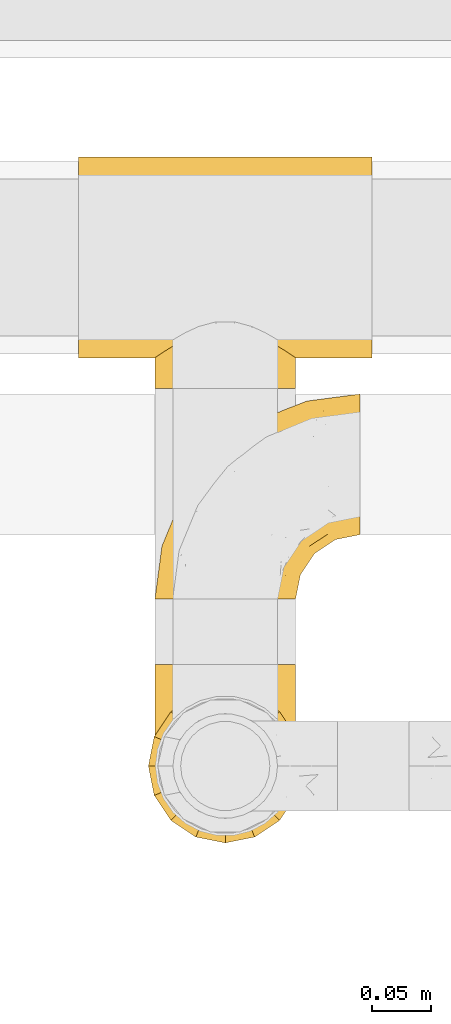
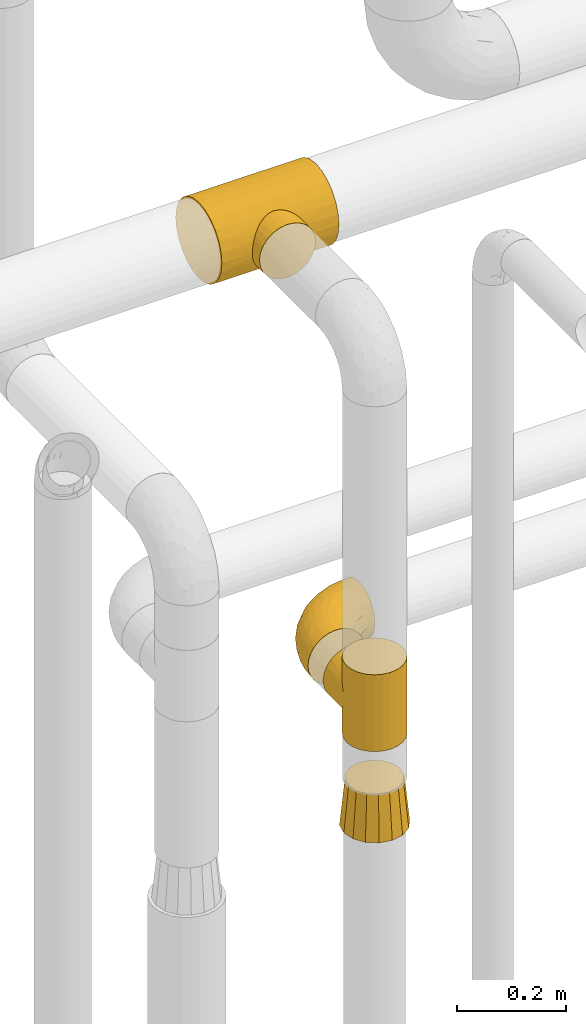
# One storey, part 460 of 827: 4 coverings.
"""IFC2X3 building model written with IfcOpenShell, lengths in millimetres."""

from ifc_helpers import new_model, entity, si_unit, converted_unit, derived_unit, direction, frame, origin, place, context, subcontext, project, spatial, faceted_brep, element, save


model = new_model("IFC2X3")

# Units and contexts
model_context = context("Model", 3, precision=0.01, world=origin(), true_north=direction((6.12303176911189e-17, 1.0)))
body_context = subcontext(model_context, "Body", "Model", "MODEL_VIEW")
ifc_project = project(units=[si_unit("LENGTHUNIT", "METRE", prefix="MILLI"), si_unit("AREAUNIT", "SQUARE_METRE"), si_unit("VOLUMEUNIT", "CUBIC_METRE"), converted_unit("PLANEANGLEUNIT", "DEGREE", entity("IfcRatioMeasure", 0.0174532925199433), si_unit("PLANEANGLEUNIT", "RADIAN"), dimensions=[0, 0, 0, 0, 0, 0, 0]), si_unit("MASSUNIT", "GRAM", prefix="KILO"), derived_unit("MASSDENSITYUNIT", [(si_unit("MASSUNIT", "GRAM", prefix="KILO"), 1), (si_unit("LENGTHUNIT", "METRE"), -3)]), derived_unit("MOMENTOFINERTIAUNIT", [(si_unit("LENGTHUNIT", "METRE"), 4)]), si_unit("TIMEUNIT", "SECOND"), si_unit("FREQUENCYUNIT", "HERTZ"), si_unit("THERMODYNAMICTEMPERATUREUNIT", "DEGREE_CELSIUS"), derived_unit("THERMALTRANSMITTANCEUNIT", [(si_unit("MASSUNIT", "GRAM", prefix="KILO"), 1), (si_unit("THERMODYNAMICTEMPERATUREUNIT", "KELVIN"), -1), (si_unit("TIMEUNIT", "SECOND"), -3)]), derived_unit("VOLUMETRICFLOWRATEUNIT", [(si_unit("LENGTHUNIT", "METRE"), 3), (si_unit("TIMEUNIT", "SECOND"), -1)]), derived_unit("MASSFLOWRATEUNIT", [(si_unit("MASSUNIT", "GRAM", prefix="KILO"), 1), (si_unit("TIMEUNIT", "SECOND"), -1)]), derived_unit("ROTATIONALFREQUENCYUNIT", [(si_unit("TIMEUNIT", "SECOND"), -1)]), si_unit("ELECTRICCURRENTUNIT", "AMPERE"), si_unit("ELECTRICVOLTAGEUNIT", "VOLT"), si_unit("POWERUNIT", "WATT"), si_unit("FORCEUNIT", "NEWTON", prefix="KILO"), si_unit("ILLUMINANCEUNIT", "LUX"), si_unit("LUMINOUSFLUXUNIT", "LUMEN"), si_unit("LUMINOUSINTENSITYUNIT", "CANDELA"), derived_unit("USERDEFINED", [(si_unit("MASSUNIT", "GRAM", prefix="KILO"), -1), (si_unit("LENGTHUNIT", "METRE"), -2), (si_unit("TIMEUNIT", "SECOND"), 3), (si_unit("LUMINOUSFLUXUNIT", "LUMEN"), 1)]), derived_unit("LINEARVELOCITYUNIT", [(si_unit("LENGTHUNIT", "METRE"), 1), (si_unit("TIMEUNIT", "SECOND"), -1)]), si_unit("PRESSUREUNIT", "PASCAL"), derived_unit("USERDEFINED", [(si_unit("LENGTHUNIT", "METRE"), -2), (si_unit("MASSUNIT", "GRAM", prefix="KILO"), 1), (si_unit("TIMEUNIT", "SECOND"), -2)]), derived_unit("LINEARFORCEUNIT", [(si_unit("MASSUNIT", "GRAM", prefix="KILO"), 1), (si_unit("LENGTHUNIT", "METRE"), 1), (si_unit("TIMEUNIT", "SECOND"), -2), (si_unit("LENGTHUNIT", "METRE"), -1)]), derived_unit("PLANARFORCEUNIT", [(si_unit("MASSUNIT", "GRAM", prefix="KILO"), 1), (si_unit("LENGTHUNIT", "METRE"), 1), (si_unit("TIMEUNIT", "SECOND"), -2), (si_unit("LENGTHUNIT", "METRE"), -2)])], contexts=[model_context])

# Site, building, storey
site_placement = place(None, origin())
site = spatial("IfcSite", under=ifc_project, at=site_placement, CompositionType="ELEMENT")
building_placement = place(site_placement, origin())
building = spatial("IfcBuilding", under=site, at=building_placement, CompositionType="ELEMENT")
storey_placement = place(building_placement, frame((0.0, 0.0, 28200.0)))
storey = spatial("IfcBuildingStorey", under=building, at=storey_placement, Name="08", CompositionType="ELEMENT", Elevation=28200.0)

# Coverings
covering_1_placement = place(storey_placement, frame((57386.84, 17438.95, 2014.0)))
element("IfcCovering", 1, at=covering_1_placement, inside=storey, Name=":ADSK_", ObjectType=":ADSK_", PredefinedType="INSULATION", context=body_context, shape_type="Brep", body=[
    faceted_brep([(119.95, 69.05, 77.99), (120.5, 61.05, 0.0), (118.47, 76.43, 0.0), (112.53, 90.77, 0.0), (115.56, 84.76, 62.29), (106.45, 99.42, 47.63), (103.08, 103.08, 0.0), (111.63, 92.28, 54.76), (120.5, 61.05, 86.0), (119.95, 69.05, 94.01), (120.5, 61.05, 172.0), (118.32, 76.98, 70.06), (99.95, 106.0, 41.05), (90.77, 112.53, 0.0), (82.79, 116.38, 30.67), (83.6, 115.5, 0.0), (76.43, 118.47, 0.0), (68.74, 119.48, 0.0), (61.05, 120.5, 0.0), (61.05, 120.5, 26.55), (68.74, 119.48, 172.0), (61.05, 120.5, 145.45), (61.05, 120.5, 172.0), (92.06, 111.76, 35.28), (72.29, 119.42, 27.62), (49.81, 119.42, 27.62), (53.35, 119.48, 0.0), (45.66, 118.47, 0.0), (39.31, 116.38, 30.66), (38.49, 115.5, 0.0), (31.32, 112.53, 0.0), (22.14, 106.0, 41.04), (19.01, 103.08, 0.0), (53.35, 119.48, 172.0), (30.03, 111.77, 35.28), (15.65, 99.43, 47.62), (10.47, 92.29, 54.76), (9.56, 90.77, 0.0), (6.53, 84.76, 62.28), (3.62, 76.43, 0.0), (2.14, 69.05, 77.99), (1.6, 61.05, 0.0), (3.77, 76.99, 70.06), (1.6, 61.05, 86.0), (2.14, 69.05, 94.01), (1.6, 61.05, 172.0), (31.32, 9.56, 172.0), (45.66, 3.62, 172.0), (61.05, 1.6, 172.0), (76.43, 3.62, 172.0), (90.77, 9.56, 172.0), (103.08, 19.01, 172.0), (112.53, 31.32, 172.0), (118.47, 45.66, 172.0), (118.47, 76.43, 172.0), (112.53, 90.77, 172.0), (103.08, 103.08, 172.0), (90.77, 112.53, 172.0), (83.6, 115.5, 172.0), (76.43, 118.47, 172.0), (45.66, 118.47, 172.0), (38.49, 115.5, 172.0), (31.32, 112.53, 172.0), (19.01, 103.08, 172.0), (9.56, 90.77, 172.0), (3.62, 76.43, 172.0), (3.62, 45.66, 172.0), (9.56, 31.32, 172.0), (19.01, 19.01, 172.0), (118.47, 45.66, 0.0), (112.53, 31.32, 0.0), (103.08, 19.01, 0.0), (90.77, 9.56, 0.0), (76.43, 3.62, 0.0), (61.05, 1.6, 0.0), (45.66, 3.62, 0.0), (31.32, 9.56, 0.0), (19.01, 19.01, 0.0), (9.56, 31.32, 0.0), (3.62, 45.66, 0.0), (118.32, 76.98, 101.94), (115.56, 84.76, 109.71), (111.63, 92.28, 117.24), (106.45, 99.42, 124.37), (99.95, 106.0, 130.95), (92.06, 111.76, 136.72), (82.79, 116.38, 141.33), (72.29, 119.42, 144.38), (49.81, 119.42, 144.38), (39.31, 116.38, 141.34), (30.03, 111.77, 136.72), (22.14, 106.0, 130.96), (15.65, 99.43, 124.38), (6.53, 84.76, 109.72), (3.77, 76.99, 101.94), (10.47, 92.29, 117.24), (120.5, 147.05, 86.0), (118.47, 147.05, 70.61), (112.53, 147.05, 56.27), (103.08, 147.05, 43.96), (90.77, 147.05, 34.51), (83.6, 147.05, 31.55), (76.43, 147.05, 28.58), (68.74, 147.05, 27.56), (61.05, 147.05, 26.55), (53.35, 147.05, 27.56), (45.66, 147.05, 28.58), (38.49, 147.05, 31.55), (31.32, 147.05, 34.51), (19.01, 147.05, 43.96), (9.56, 147.05, 56.27), (3.62, 147.05, 70.61), (1.6, 147.05, 86.0), (3.62, 147.05, 101.39), (9.56, 147.05, 115.72), (19.01, 147.05, 128.04), (31.32, 147.05, 137.49), (38.49, 147.05, 140.45), (45.66, 147.05, 143.42), (53.35, 147.05, 144.44), (61.05, 147.05, 145.45), (68.74, 147.05, 144.44), (76.43, 147.05, 143.42), (83.6, 147.05, 140.45), (90.77, 147.05, 137.49), (103.08, 147.05, 128.04), (112.53, 147.05, 115.72), (118.47, 147.05, 101.39)], [[[0, 1, 2]], [[2, 3, 4]], [[5, 3, 6]], [[5, 7, 3]], [[0, 8, 1]], [[8, 9, 10]], [[4, 11, 2]], [[7, 4, 3]], [[0, 2, 11]], [[12, 6, 13]], [[14, 13, 15, 16]], [[17, 18, 19]], [[20, 21, 22]], [[23, 12, 13]], [[24, 14, 16]], [[24, 17, 19]], [[24, 16, 17]], [[23, 13, 14]], [[6, 12, 5]], [[25, 26, 27]], [[28, 27, 29, 30]], [[31, 30, 32]], [[19, 26, 25]], [[19, 18, 26]], [[22, 21, 33]], [[34, 28, 30]], [[31, 34, 30]], [[25, 27, 28]], [[32, 35, 31]], [[36, 35, 37]], [[37, 35, 32]], [[38, 37, 39]], [[40, 39, 41]], [[38, 36, 37]], [[40, 42, 39]], [[43, 40, 41]], [[44, 43, 45]], [[38, 39, 42]], [[46, 47, 48, 49, 50, 51, 52, 53, 10, 54, 55, 56, 57, 58, 59, 20, 22, 33, 60, 61, 62, 63, 64, 65, 45, 66, 67, 68]], [[1, 69, 70, 71, 72, 73, 74, 75, 76, 77, 78, 79, 41, 39, 37, 32, 30, 29, 27, 26, 18, 17, 16, 15, 13, 6, 3, 2]], [[72, 71, 51, 50]], [[48, 74, 73, 49]], [[49, 73, 72, 50]], [[52, 70, 69, 53]], [[1, 8, 10, 53, 69]], [[51, 71, 70, 52]], [[80, 81, 54]], [[9, 80, 54]], [[10, 9, 54]], [[55, 82, 83]], [[55, 54, 81]], [[55, 83, 56]], [[82, 55, 81]], [[84, 85, 57]], [[86, 59, 58, 57]], [[86, 87, 59]], [[21, 20, 87]], [[85, 86, 57]], [[56, 84, 57]], [[87, 20, 59]], [[84, 56, 83]], [[88, 89, 60]], [[88, 60, 33]], [[90, 91, 62]], [[89, 62, 61, 60]], [[89, 90, 62]], [[88, 33, 21]], [[91, 63, 62]], [[91, 92, 63]], [[93, 94, 65]], [[94, 44, 65]], [[92, 95, 64]], [[93, 64, 95]], [[93, 65, 64]], [[44, 45, 65]], [[92, 64, 63]], [[43, 41, 79, 66, 45]], [[66, 79, 78, 67]], [[78, 77, 68, 67]], [[68, 77, 76, 46]], [[46, 76, 75, 47]], [[47, 75, 74, 48]], [[96, 97, 98, 99, 100, 101, 102, 103, 104, 105, 106, 107, 108, 109, 110, 111, 112, 113, 114, 115, 116, 117, 118, 119, 120, 121, 122, 123, 124, 125, 126, 127]], [[103, 102, 24]], [[100, 99, 12]], [[101, 100, 14, 102]], [[19, 103, 24]], [[19, 104, 103]], [[23, 14, 100]], [[12, 23, 100]], [[24, 102, 14]], [[99, 5, 12]], [[7, 5, 98]], [[98, 5, 99]], [[4, 98, 97]], [[0, 97, 96]], [[4, 7, 98]], [[0, 11, 97]], [[8, 0, 96]], [[4, 97, 11]], [[9, 96, 127]], [[127, 126, 81]], [[83, 126, 125]], [[83, 82, 126]], [[9, 8, 96]], [[81, 80, 127]], [[82, 81, 126]], [[9, 127, 80]], [[84, 125, 124]], [[86, 124, 123, 122]], [[121, 120, 21]], [[85, 84, 124]], [[87, 86, 122]], [[87, 121, 21]], [[87, 122, 121]], [[85, 124, 86]], [[125, 84, 83]], [[88, 119, 118]], [[89, 118, 117, 116]], [[91, 116, 115]], [[21, 119, 88]], [[21, 120, 119]], [[90, 89, 116]], [[91, 90, 116]], [[88, 118, 89]], [[115, 92, 91]], [[95, 92, 114]], [[114, 92, 115]], [[93, 114, 113]], [[44, 113, 112]], [[93, 95, 114]], [[44, 94, 113]], [[43, 44, 112]], [[93, 113, 94]], [[40, 112, 111]], [[111, 110, 38]], [[35, 110, 109]], [[35, 36, 110]], [[40, 43, 112]], [[38, 42, 111]], [[36, 38, 110]], [[40, 111, 42]], [[31, 109, 108]], [[28, 108, 107, 106]], [[105, 104, 19]], [[34, 31, 108]], [[25, 28, 106]], [[25, 105, 19]], [[25, 106, 105]], [[34, 108, 28]], [[109, 31, 35]]]),
])
covering_2_placement = place(storey_placement, frame((57386.84, 17639.5, 2038.95)))
element("IfcCovering", 2, at=covering_2_placement, inside=storey, Name=":ADSK_", ObjectType=":ADSK_", PredefinedType="INSULATION", context=body_context, shape_type="Brep", body=[
    faceted_brep([(47.81, 1.6, 119.0), (35.25, 1.6, 114.61), (23.97, 1.6, 107.52), (14.56, 1.6, 98.11), (7.48, 1.6, 86.83), (3.08, 1.6, 74.26), (1.6, 1.6, 61.05), (3.09, 1.6, 47.81), (7.48, 1.6, 35.25), (14.57, 1.6, 23.97), (23.99, 1.6, 14.56), (35.26, 1.6, 7.48), (47.83, 1.6, 3.08), (61.05, 1.6, 1.6), (74.28, 1.6, 3.09), (86.84, 1.6, 7.48), (98.12, 1.6, 14.57), (107.53, 1.6, 23.99), (114.61, 1.6, 35.26), (119.01, 1.6, 47.83), (120.5, 1.6, 61.05), (119.0, 1.6, 74.28), (114.61, 1.6, 86.84), (107.52, 1.6, 98.12), (98.11, 1.6, 107.53), (86.83, 1.6, 114.61), (74.26, 1.6, 119.01), (61.05, 1.6, 120.5), (175.05, 58.17, 45.66), (175.05, 64.11, 31.32), (175.05, 73.56, 19.01), (175.05, 85.87, 9.56), (175.05, 100.21, 3.62), (175.05, 115.6, 1.6), (175.05, 130.98, 3.62), (175.05, 145.32, 9.56), (175.05, 157.63, 19.01), (175.05, 167.08, 31.32), (175.05, 173.02, 45.66), (175.05, 175.05, 61.05), (175.05, 173.02, 76.43), (175.05, 167.08, 90.77), (175.05, 157.63, 103.08), (175.05, 145.32, 112.53), (175.05, 130.98, 118.47), (175.05, 115.6, 120.5), (175.05, 100.21, 118.47), (175.05, 85.87, 112.53), (175.05, 73.56, 103.08), (175.05, 64.11, 90.77), (175.05, 58.17, 76.43), (175.05, 56.15, 61.05), (144.29, 160.93, 95.74), (133.4, 165.97, 82.17), (108.85, 151.16, 93.88), (137.58, 169.95, 71.8), (130.15, 169.14, 61.05), (33.43, 47.74, 109.14), (48.64, 81.62, 108.65), (32.13, 69.65, 100.7), (71.77, 137.09, 79.94), (88.32, 151.81, 61.05), (52.4, 124.24, 61.05), (105.93, 120.32, 115.7), (128.22, 136.76, 112.92), (102.42, 129.05, 110.7), (138.98, 127.83, 117.93), (114.96, 111.19, 119.47), (25.03, 73.49, 89.21), (14.44, 40.92, 91.01), (103.12, 154.8, 83.0), (109.71, 161.22, 71.74), (133.1, 148.51, 106.1), (7.51, 46.49, 61.05), (9.66, 43.55, 79.17), (38.78, 105.65, 76.32), (19.81, 75.81, 73.8), (73.56, 102.22, 112.99), (65.59, 111.05, 104.29), (53.66, 31.64, 119.46), (65.45, 61.68, 119.47), (56.32, 70.72, 115.7), (108.04, 93.82, 120.5), (123.93, 101.92, 120.5), (139.82, 110.02, 120.5), (24.83, 88.32, 61.05), (42.35, 34.61, 115.97), (20.84, 34.27, 101.43), (74.42, 130.32, 94.14), (46.21, 101.6, 94.58), (96.34, 135.16, 104.07), (83.99, 92.65, 118.63), (82.82, 68.6, 120.5), (95.43, 81.21, 120.5), (63.36, 16.21, 120.5), (66.62, 36.82, 120.5), (74.72, 52.71, 120.5), (160.43, 113.28, 120.5), (91.97, 49.51, 117.67), (88.98, 24.29, 114.99), (102.6, 33.37, 109.18), (155.55, 97.47, 118.26), (141.61, 92.13, 117.87), (123.71, 65.64, 111.2), (136.88, 63.0, 103.41), (141.73, 72.44, 108.57), (108.95, 54.52, 112.76), (132.33, 38.38, 75.65), (131.77, 46.09, 89.98), (122.46, 30.11, 85.51), (124.65, 22.47, 61.05), (123.29, 22.86, 73.87), (158.35, 82.06, 111.26), (153.2, 68.74, 101.69), (147.72, 56.57, 88.74), (162.85, 60.39, 86.0), (158.54, 55.21, 74.52), (144.02, 47.46, 70.92), (154.17, 51.99, 61.05), (76.05, 19.27, 118.96), (98.34, 66.98, 119.01), (113.97, 75.5, 117.67), (117.88, 15.03, 82.93), (111.71, 21.65, 96.71), (120.52, 38.96, 96.25), (101.36, 16.17, 106.01), (79.3, 36.61, 119.26), (112.64, 42.47, 105.56), (136.47, 40.17, 61.05), (138.23, 81.33, 114.42), (124.93, 89.72, 119.14), (123.97, 52.09, 102.94), (136.9, 62.98, 18.7), (123.98, 52.08, 19.16), (123.74, 65.65, 10.9), (148.89, 89.82, 5.81), (124.93, 89.72, 2.95), (138.07, 97.2, 2.72), (132.31, 38.35, 46.46), (108.96, 54.51, 9.34), (82.82, 68.6, 1.6), (95.43, 81.21, 1.6), (98.34, 66.99, 3.08), (158.54, 55.21, 47.58), (88.99, 24.29, 7.11), (162.86, 60.39, 36.09), (101.37, 16.17, 16.09), (111.72, 21.63, 25.4), (155.55, 97.47, 3.83), (160.43, 113.28, 1.6), (113.97, 75.5, 4.42), (153.21, 68.74, 20.4), (144.01, 47.46, 51.15), (158.35, 82.06, 10.83), (112.65, 42.47, 16.53), (120.51, 38.93, 25.84), (123.29, 22.84, 48.24), (66.62, 36.82, 1.6), (74.72, 52.71, 1.6), (79.32, 36.62, 2.83), (63.36, 16.21, 1.6), (122.45, 30.08, 36.6), (117.88, 15.02, 39.17), (131.76, 46.08, 32.11), (147.73, 56.57, 33.35), (123.93, 101.92, 1.6), (91.99, 49.52, 4.42), (102.61, 33.36, 12.92), (76.07, 19.28, 3.14), (141.72, 72.43, 13.52), (108.04, 93.82, 1.6), (139.82, 110.02, 1.6), (138.23, 81.33, 7.67), (108.85, 151.16, 28.21), (144.29, 160.93, 26.35), (133.1, 148.51, 15.99), (128.22, 136.76, 9.17), (137.58, 169.95, 50.29), (133.4, 165.97, 39.92), (109.71, 161.22, 50.35), (114.96, 111.19, 2.62), (56.32, 70.72, 6.39), (53.67, 31.66, 2.63), (42.36, 34.61, 6.11), (65.59, 111.05, 17.8), (48.62, 81.57, 13.43), (46.21, 101.58, 27.5), (65.45, 61.68, 2.62), (83.99, 92.65, 3.46), (138.98, 127.83, 4.16), (103.12, 154.8, 39.09), (32.14, 69.65, 21.38), (20.85, 34.27, 20.65), (25.03, 73.47, 32.87), (12.63, 32.52, 31.06), (38.78, 105.65, 45.77), (71.77, 137.09, 42.15), (33.44, 47.72, 12.94), (102.42, 129.05, 11.39), (73.52, 102.2, 9.11), (9.67, 43.54, 42.91), (96.34, 135.17, 18.03), (74.41, 130.32, 27.95), (20.85, 76.08, 45.01), (105.93, 120.32, 6.39)], [[[0, 1, 2, 3, 4, 5, 6, 7, 8, 9, 10, 11, 12, 13, 14, 15, 16, 17, 18, 19, 20, 21, 22, 23, 24, 25, 26, 27]], [[28, 29, 30, 31, 32, 33, 34, 35, 36, 37, 38, 39, 40, 41, 42, 43, 44, 45, 46, 47, 48, 49, 50, 51]], [[52, 53, 54]], [[55, 39, 56]], [[57, 58, 59]], [[60, 61, 62]], [[63, 64, 65]], [[66, 63, 67]], [[59, 68, 69]], [[53, 70, 54]], [[41, 40, 53]], [[53, 71, 70]], [[72, 42, 52]], [[42, 41, 52]], [[73, 5, 74]], [[68, 75, 76]], [[43, 72, 64]], [[45, 44, 66]], [[58, 77, 78]], [[79, 80, 81]], [[67, 82, 83, 84]], [[75, 62, 85]], [[1, 0, 86]], [[2, 87, 3]], [[57, 87, 2]], [[42, 72, 43]], [[5, 4, 74]], [[2, 1, 57]], [[69, 3, 87]], [[5, 73, 6]], [[59, 87, 57]], [[66, 64, 63]], [[88, 89, 78]], [[54, 88, 90]], [[75, 60, 62]], [[91, 92, 93, 82]], [[79, 27, 94, 95]], [[76, 73, 74]], [[80, 95, 96, 92]], [[57, 1, 86]], [[56, 71, 55]], [[77, 91, 63]], [[80, 91, 81]], [[67, 91, 82]], [[71, 56, 61]], [[69, 4, 3]], [[74, 69, 68]], [[75, 89, 60]], [[80, 79, 95]], [[81, 57, 86]], [[76, 75, 85]], [[89, 68, 59]], [[58, 57, 81]], [[59, 58, 89]], [[90, 88, 78]], [[75, 68, 89]], [[70, 88, 54]], [[60, 89, 88]], [[77, 58, 81]], [[89, 58, 78]], [[91, 77, 81]], [[77, 63, 65]], [[78, 77, 65]], [[54, 90, 72]], [[91, 80, 92]], [[79, 81, 86]], [[86, 0, 79]], [[27, 79, 0]], [[66, 84, 97, 45]], [[91, 67, 63]], [[84, 66, 67]], [[64, 44, 43]], [[64, 66, 44]], [[65, 72, 90]], [[53, 52, 41]], [[72, 52, 54]], [[72, 65, 64]], [[65, 90, 78]], [[60, 71, 61]], [[55, 71, 53]], [[71, 60, 70]], [[88, 70, 60]], [[53, 40, 55]], [[39, 55, 40]], [[4, 69, 74]], [[59, 69, 87]], [[73, 76, 85]], [[68, 76, 74]], [[98, 99, 100]], [[84, 101, 97]], [[84, 83, 102]], [[97, 101, 46]], [[103, 104, 105]], [[47, 46, 101]], [[106, 98, 100]], [[107, 108, 109]], [[110, 107, 111]], [[112, 48, 47]], [[48, 113, 49]], [[113, 114, 115]], [[116, 51, 50]], [[115, 50, 49]], [[116, 117, 118]], [[119, 95, 94]], [[111, 107, 109]], [[93, 120, 121]], [[122, 123, 22]], [[121, 106, 103]], [[25, 24, 99]], [[114, 113, 104]], [[124, 109, 108]], [[25, 119, 26]], [[27, 26, 94]], [[112, 113, 48]], [[125, 123, 100]], [[24, 125, 99]], [[111, 20, 110]], [[109, 122, 111]], [[119, 94, 26]], [[99, 126, 119]], [[123, 124, 127]], [[117, 107, 128]], [[122, 22, 21]], [[129, 130, 121]], [[123, 23, 22]], [[92, 98, 120]], [[127, 106, 100]], [[23, 125, 24]], [[93, 121, 82]], [[119, 126, 95]], [[21, 20, 111]], [[123, 122, 109]], [[21, 111, 122]], [[107, 110, 128]], [[117, 128, 118]], [[107, 117, 108]], [[104, 108, 114]], [[124, 108, 131]], [[25, 99, 119]], [[96, 126, 98]], [[98, 92, 96]], [[123, 125, 23]], [[99, 125, 100]], [[103, 106, 131]], [[120, 106, 121]], [[83, 82, 130]], [[101, 102, 112]], [[130, 102, 83]], [[121, 130, 82]], [[102, 130, 129]], [[101, 112, 47]], [[112, 129, 105]], [[118, 51, 116]], [[108, 117, 114]], [[115, 116, 50]], [[114, 117, 116]], [[112, 102, 129]], [[102, 101, 84]], [[104, 103, 131]], [[129, 121, 103]], [[104, 131, 108]], [[105, 104, 113]], [[112, 105, 113]], [[103, 105, 129]], [[127, 124, 131]], [[123, 109, 124]], [[106, 127, 131]], [[123, 127, 100]], [[98, 126, 99]], [[95, 126, 96]], [[113, 115, 49]], [[116, 115, 114]], [[46, 45, 97]], [[92, 120, 93]], [[106, 120, 98]], [[132, 133, 134]], [[135, 136, 137]], [[110, 138, 128]], [[139, 134, 133]], [[140, 141, 142]], [[143, 51, 118]], [[16, 15, 144]], [[28, 145, 29]], [[146, 147, 17]], [[144, 146, 16]], [[31, 148, 32]], [[148, 149, 32]], [[139, 142, 150]], [[30, 29, 151]], [[152, 143, 118]], [[31, 30, 153]], [[139, 133, 154]], [[155, 154, 133]], [[110, 156, 138]], [[142, 141, 150]], [[20, 19, 156]], [[157, 158, 159]], [[14, 13, 160]], [[17, 16, 146]], [[161, 162, 147]], [[18, 162, 19]], [[152, 163, 164]], [[137, 136, 165]], [[144, 166, 167]], [[133, 163, 155]], [[144, 167, 146]], [[147, 18, 17]], [[29, 145, 151]], [[128, 138, 152]], [[160, 157, 168]], [[160, 168, 14]], [[14, 168, 15]], [[167, 166, 139]], [[151, 169, 153]], [[162, 156, 19]], [[141, 170, 150]], [[164, 163, 132]], [[147, 162, 18]], [[156, 162, 161]], [[156, 161, 138]], [[156, 110, 20]], [[163, 138, 161]], [[128, 152, 118]], [[155, 163, 161]], [[132, 163, 133]], [[159, 166, 144]], [[144, 15, 168]], [[166, 158, 140]], [[168, 159, 144]], [[147, 146, 167]], [[142, 139, 166]], [[134, 139, 150]], [[135, 31, 153]], [[136, 170, 165]], [[136, 150, 170]], [[148, 137, 171]], [[150, 136, 172]], [[151, 153, 30]], [[136, 135, 172]], [[163, 152, 138]], [[143, 28, 51]], [[152, 164, 143]], [[145, 143, 164]], [[171, 137, 165]], [[137, 148, 135]], [[31, 135, 148]], [[172, 135, 153]], [[150, 172, 134]], [[132, 169, 151]], [[169, 134, 172]], [[164, 132, 151]], [[134, 169, 132]], [[153, 169, 172]], [[161, 147, 155]], [[154, 147, 167]], [[147, 154, 155]], [[139, 154, 167]], [[157, 159, 168]], [[166, 159, 158]], [[143, 145, 28]], [[151, 145, 164]], [[149, 148, 171]], [[149, 33, 32]], [[140, 142, 166]], [[173, 174, 175]], [[35, 34, 176]], [[177, 178, 179]], [[180, 171, 165, 170]], [[181, 182, 183]], [[184, 185, 186]], [[187, 188, 140]], [[189, 33, 149, 171]], [[178, 190, 179]], [[34, 189, 176]], [[39, 38, 177]], [[191, 192, 193]], [[9, 8, 194]], [[174, 178, 37]], [[38, 37, 178]], [[35, 175, 36]], [[195, 62, 196]], [[180, 189, 171]], [[37, 36, 174]], [[183, 11, 197]], [[188, 170, 141, 140]], [[184, 198, 199]], [[8, 7, 200]], [[201, 184, 202]], [[13, 12, 182]], [[181, 185, 199]], [[183, 12, 11]], [[62, 195, 85]], [[202, 184, 186]], [[10, 197, 11]], [[199, 188, 181]], [[194, 8, 200]], [[203, 195, 193]], [[62, 61, 196]], [[197, 191, 185]], [[10, 192, 197]], [[7, 6, 73]], [[197, 192, 191]], [[192, 10, 9]], [[193, 192, 194]], [[7, 73, 200]], [[179, 61, 56]], [[203, 73, 85]], [[187, 140, 158, 157]], [[180, 188, 204]], [[179, 196, 61]], [[197, 181, 183]], [[181, 187, 182]], [[201, 173, 175]], [[203, 193, 200]], [[186, 191, 193]], [[197, 185, 181]], [[193, 195, 186]], [[196, 186, 195]], [[186, 196, 202]], [[190, 202, 196]], [[186, 185, 191]], [[199, 185, 184]], [[198, 184, 201]], [[188, 199, 204]], [[173, 201, 202]], [[175, 176, 198]], [[188, 180, 170]], [[189, 180, 204]], [[189, 204, 176]], [[189, 34, 33]], [[187, 157, 182]], [[188, 187, 181]], [[182, 157, 160, 13]], [[12, 183, 182]], [[198, 176, 204]], [[35, 176, 175]], [[175, 174, 36]], [[178, 174, 173]], [[199, 198, 204]], [[175, 198, 201]], [[177, 179, 56]], [[178, 173, 190]], [[202, 190, 173]], [[196, 179, 190]], [[39, 177, 56]], [[38, 178, 177]], [[193, 194, 200]], [[9, 194, 192]], [[73, 203, 200]], [[85, 195, 203]]]),
])
covering_3_placement = place(storey_placement, frame((57323.89, 17819.1, 2813.52)))
element("IfcCovering", 3, at=covering_3_placement, inside=storey, Name=":ADSK_", ObjectType=":ADSK_", PredefinedType="INSULATION", context=body_context, shape_type="Brep", body=[
    faceted_brep([(248.0, 184.48, 44.02), (248.0, 192.96, 64.48), (248.0, 195.85, 86.45), (248.0, 192.96, 108.41), (248.0, 184.48, 128.87), (248.0, 171.0, 146.44), (248.0, 153.43, 159.93), (248.0, 132.96, 168.4), (248.0, 111.0, 171.3), (248.0, 89.04, 168.4), (248.0, 68.58, 159.93), (248.0, 51.0, 146.44), (248.0, 37.52, 128.87), (248.0, 33.28, 118.64), (248.0, 29.04, 108.41), (248.0, 27.6, 97.43), (248.0, 26.15, 86.45), (248.0, 27.6, 75.46), (248.0, 29.04, 64.48), (248.0, 33.28, 54.25), (248.0, 37.52, 44.02), (248.0, 51.0, 26.45), (248.0, 68.58, 12.96), (248.0, 89.04, 4.49), (248.0, 111.0, 1.6), (248.0, 132.96, 4.49), (248.0, 153.43, 12.96), (248.0, 171.0, 26.45), (0.0, 111.0, 171.3), (0.0, 132.96, 168.4), (0.0, 153.43, 159.93), (0.0, 171.0, 146.44), (0.0, 184.48, 128.87), (0.0, 192.96, 108.41), (0.0, 195.85, 86.45), (0.0, 192.96, 64.48), (0.0, 184.48, 44.02), (0.0, 171.0, 26.45), (0.0, 153.43, 12.96), (0.0, 132.96, 4.49), (0.0, 111.0, 1.6), (0.0, 89.04, 4.49), (0.0, 68.58, 12.96), (0.0, 51.0, 26.45), (0.0, 37.52, 44.02), (0.0, 33.28, 54.25), (0.0, 29.04, 64.48), (0.0, 27.6, 75.46), (0.0, 26.15, 86.45), (0.0, 27.6, 97.43), (0.0, 29.04, 108.41), (0.0, 33.28, 118.64), (0.0, 37.52, 128.87), (0.0, 51.0, 146.44), (0.0, 68.58, 159.93), (0.0, 89.04, 168.4), (90.83, 41.97, 135.78), (100.82, 46.17, 141.19), (178.67, 29.43, 109.81), (173.1, 33.05, 119.96), (112.01, 49.28, 144.67), (65.78, 27.01, 98.47), (124.0, 50.46, 145.9), (135.99, 49.28, 144.67), (183.45, 26.15, 86.45), (182.22, 27.01, 98.47), (147.18, 46.17, 141.19), (157.17, 41.97, 135.78), (74.9, 33.05, 119.96), (69.33, 29.43, 109.81), (82.14, 37.4, 128.66), (64.55, 26.15, 86.45), (165.86, 37.4, 128.66), (65.78, 27.01, 74.42), (74.9, 33.05, 52.93), (69.33, 29.43, 63.08), (82.14, 37.4, 44.23), (182.22, 27.01, 74.42), (178.67, 29.43, 63.08), (173.1, 33.05, 52.93), (165.86, 37.4, 44.23), (90.83, 41.97, 37.11), (100.82, 46.17, 31.7), (124.0, 50.46, 27.0), (112.01, 49.28, 28.22), (157.17, 41.97, 37.11), (147.18, 46.17, 31.7), (135.99, 49.28, 28.22), (124.0, 0.0, 145.9), (108.61, 0.0, 143.87), (94.28, 0.0, 137.93), (81.96, 0.0, 128.48), (72.51, 0.0, 116.17), (66.58, 0.0, 101.83), (64.55, 0.0, 86.45), (66.58, 0.0, 71.06), (72.51, 0.0, 56.72), (81.96, 0.0, 44.41), (94.28, 0.0, 34.96), (108.61, 0.0, 29.02), (124.0, 0.0, 27.0), (139.39, 0.0, 29.02), (153.73, 0.0, 34.96), (166.04, 0.0, 44.41), (175.49, 0.0, 56.72), (181.42, 0.0, 71.06), (183.45, 0.0, 86.45), (181.42, 0.0, 101.83), (175.49, 0.0, 116.17), (166.04, 0.0, 128.48), (153.73, 0.0, 137.93), (139.39, 0.0, 143.87)], [[[0, 1, 2, 3, 4, 5, 6, 7, 8, 9, 10, 11, 12, 13, 14, 15, 16, 17, 18, 19, 20, 21, 22, 23, 24, 25, 26, 27]], [[28, 29, 30, 31, 32, 33, 34, 35, 36, 37, 38, 39, 40, 41, 42, 43, 44, 45, 46, 47, 48, 49, 50, 51, 52, 53, 54, 55]], [[32, 31, 5, 4]], [[2, 34, 33, 3]], [[3, 33, 32, 4]], [[6, 30, 29, 7]], [[7, 29, 28, 8]], [[5, 31, 30, 6]], [[55, 9, 8, 28]], [[54, 10, 9, 55]], [[53, 56, 57]], [[56, 53, 52]], [[58, 13, 59]], [[57, 60, 53]], [[61, 50, 49]], [[54, 53, 62]], [[53, 60, 62]], [[62, 11, 10]], [[62, 63, 11]], [[64, 15, 65]], [[66, 67, 11]], [[68, 52, 51]], [[63, 66, 11]], [[62, 10, 54]], [[11, 67, 12]], [[51, 69, 68]], [[69, 51, 50]], [[68, 70, 52]], [[48, 71, 49]], [[64, 16, 15]], [[61, 49, 71]], [[50, 61, 69]], [[72, 59, 12]], [[13, 58, 14]], [[59, 13, 12]], [[12, 67, 72]], [[15, 14, 65]], [[65, 14, 58]], [[70, 56, 52]], [[48, 47, 71]], [[16, 64, 17]], [[73, 47, 46]], [[45, 44, 74]], [[75, 46, 45]], [[44, 76, 74]], [[46, 75, 73]], [[77, 17, 64]], [[77, 78, 18]], [[79, 19, 78]], [[19, 18, 78]], [[20, 79, 80]], [[76, 44, 81]], [[82, 81, 43]], [[71, 47, 73]], [[83, 84, 43]], [[82, 43, 84]], [[79, 20, 19]], [[42, 41, 23, 22]], [[83, 42, 22]], [[43, 42, 83]], [[81, 44, 43]], [[23, 41, 40, 24]], [[21, 85, 86]], [[75, 45, 74]], [[21, 20, 85]], [[20, 80, 85]], [[86, 87, 21]], [[77, 18, 17]], [[87, 83, 21]], [[83, 22, 21]], [[25, 39, 38, 26]], [[26, 38, 37, 27]], [[40, 39, 25, 24]], [[0, 36, 35, 1]], [[1, 35, 34, 2]], [[27, 37, 36, 0]], [[88, 89, 90, 91, 92, 93, 94, 95, 96, 97, 98, 99, 100, 101, 102, 103, 104, 105, 106, 107, 108, 109, 110, 111]], [[61, 94, 93]], [[93, 92, 69]], [[91, 68, 92]], [[61, 71, 94]], [[68, 69, 92]], [[61, 93, 69]], [[91, 70, 68]], [[70, 91, 56]], [[56, 91, 90]], [[57, 90, 89]], [[60, 89, 88]], [[56, 90, 57]], [[60, 57, 89]], [[62, 60, 88]], [[63, 88, 111]], [[111, 110, 66]], [[109, 67, 110]], [[109, 72, 67]], [[62, 88, 63]], [[63, 111, 66]], [[110, 67, 66]], [[59, 109, 108]], [[58, 108, 107]], [[65, 107, 106]], [[58, 59, 108]], [[64, 65, 106]], [[58, 107, 65]], [[109, 59, 72]], [[77, 106, 105]], [[104, 103, 79]], [[78, 105, 104]], [[77, 64, 106]], [[79, 78, 104]], [[77, 105, 78]], [[103, 80, 79]], [[80, 103, 85]], [[85, 103, 102]], [[86, 102, 101]], [[87, 101, 100]], [[85, 102, 86]], [[87, 86, 101]], [[83, 87, 100]], [[84, 100, 99]], [[99, 98, 82]], [[97, 81, 98]], [[97, 76, 81]], [[83, 100, 84]], [[84, 99, 82]], [[98, 81, 82]], [[74, 97, 96]], [[75, 96, 95]], [[73, 95, 94]], [[75, 74, 96]], [[71, 73, 94]], [[75, 95, 73]], [[97, 74, 76]]]),
])
covering_4_placement = place(storey_placement, frame((57381.29, 17433.4, 1813.45)))
element("IfcCovering", 4, at=covering_4_placement, inside=storey, Name=":ADSK_", ObjectType=":ADSK_", PredefinedType="INSULATION", context=body_context, shape_type="Brep", body=[
    faceted_brep([(91.47, 6.54, 0.0), (81.18, 4.5, 0.0), (66.6, 1.6, 0.0), (52.01, 4.5, 0.0), (41.72, 6.54, 0.0), (31.18, 13.59, 0.0), (20.63, 20.63, 0.0), (13.59, 31.18, 0.0), (6.54, 41.72, 0.0), (4.5, 52.01, 0.0), (1.6, 66.6, 0.0), (4.5, 81.18, 0.0), (6.54, 91.47, 0.0), (13.59, 102.01, 0.0), (20.63, 112.56, 0.0), (31.18, 119.6, 0.0), (41.72, 126.65, 0.0), (52.01, 128.69, 0.0), (66.6, 131.6, 0.0), (81.18, 128.69, 0.0), (91.47, 126.65, 0.0), (102.01, 119.6, 0.0), (112.56, 112.56, 0.0), (119.6, 102.01, 0.0), (126.65, 91.47, 0.0), (128.69, 81.18, 0.0), (131.6, 66.6, 0.0), (128.69, 52.01, 0.0), (126.65, 41.72, 0.0), (119.6, 31.18, 0.0), (112.56, 20.63, 0.0), (102.01, 13.59, 0.0), (66.6, 11.6, 102.0), (77.12, 13.69, 102.0), (87.64, 15.78, 102.0), (96.56, 21.74, 102.0), (105.49, 27.7, 102.0), (111.45, 36.63, 102.0), (117.41, 45.55, 102.0), (119.5, 56.07, 102.0), (121.6, 66.6, 102.0), (119.5, 77.12, 102.0), (117.41, 87.64, 102.0), (111.45, 96.56, 102.0), (105.49, 105.49, 102.0), (96.56, 111.45, 102.0), (87.64, 117.41, 102.0), (77.12, 119.5, 102.0), (66.6, 121.6, 102.0), (56.07, 119.5, 102.0), (45.55, 117.41, 102.0), (36.63, 111.45, 102.0), (27.7, 105.49, 102.0), (21.74, 96.56, 102.0), (15.78, 87.64, 102.0), (13.69, 77.12, 102.0), (11.6, 66.6, 102.0), (13.69, 56.07, 102.0), (15.78, 45.55, 102.0), (21.74, 36.63, 102.0), (27.7, 27.7, 102.0), (36.63, 21.74, 102.0), (45.55, 15.78, 102.0), (56.07, 13.69, 102.0)], [[[0, 1, 2, 3, 4, 5, 6, 7, 8, 9, 10, 11, 12, 13, 14, 15, 16, 17, 18, 19, 20, 21, 22, 23, 24, 25, 26, 27, 28, 29, 30, 31]], [[32, 33, 34, 35, 36, 37, 38, 39, 40, 41, 42, 43, 44, 45, 46, 47, 48, 49, 50, 51, 52, 53, 54, 55, 56, 57, 58, 59, 60, 61, 62, 63]], [[38, 28, 27, 26, 40, 39]], [[36, 30, 29, 28, 38, 37]], [[34, 0, 31, 30, 36, 35]], [[33, 32, 2, 1, 0, 34]], [[62, 4, 3, 2, 32, 63]], [[60, 6, 5, 4, 62, 61]], [[58, 8, 7, 6, 60, 59]], [[57, 56, 10, 9, 8, 58]], [[54, 12, 11, 10, 56, 55]], [[52, 14, 13, 12, 54, 53]], [[50, 16, 15, 14, 52, 51]], [[49, 48, 18, 17, 16, 50]], [[46, 20, 19, 18, 48, 47]], [[44, 22, 21, 20, 46, 45]], [[42, 24, 23, 22, 44, 43]], [[41, 40, 26, 25, 24, 42]]]),
])

save(model, "model.ifc")
